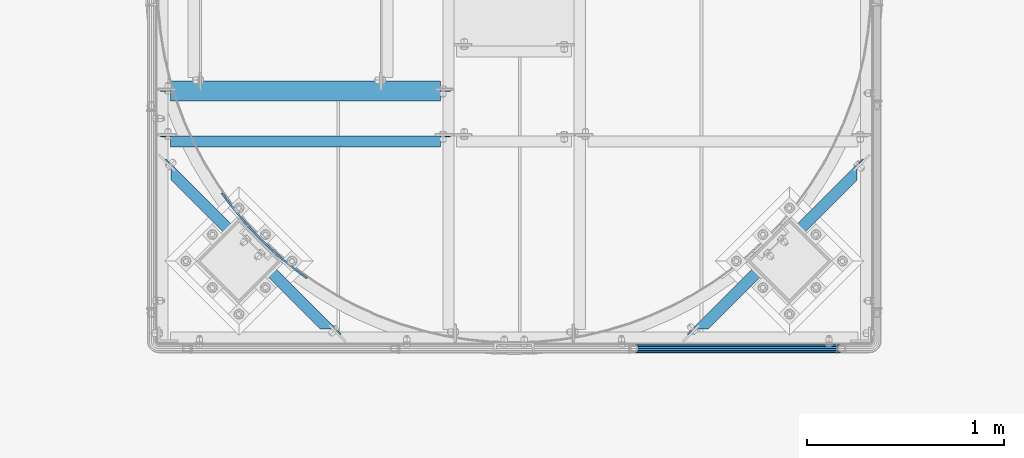
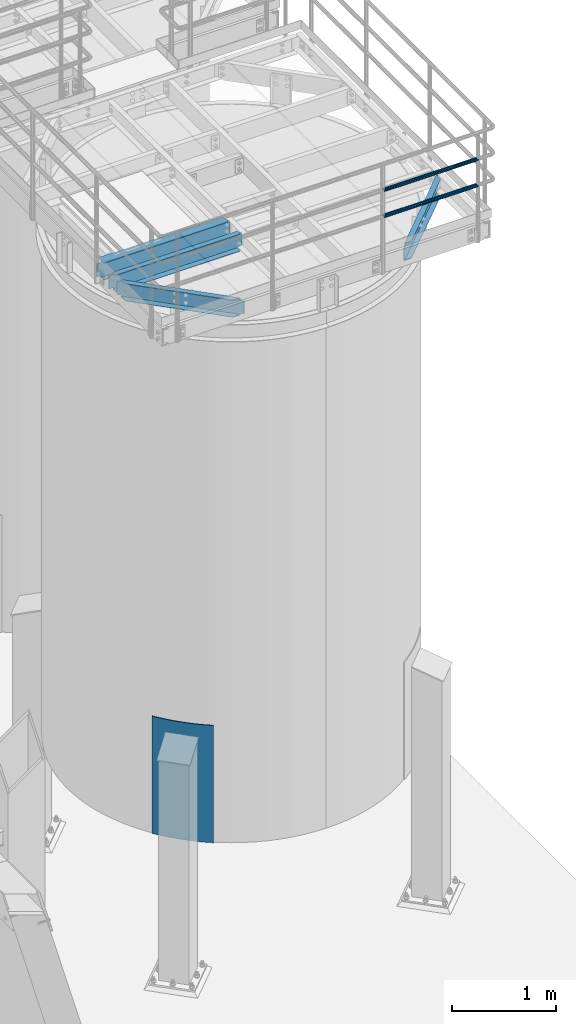
# One storey, part 915 of 1876: 7 beams, 6 elements without a shape of their own.
"""IFC2X3 building model written with IfcOpenShell, lengths in millimetres."""

from ifc_helpers import new_model, si_unit, frame, origin_with_axes, place, context, subcontext, project, spatial, faceted_brep, material, type_object, element, aggregate, save


model = new_model("IFC2X3")

# Units and contexts
model_context = context("Model", 3, precision=1e-05, world=origin_with_axes())
body_context = subcontext(model_context, "Body", "Model", "MODEL_VIEW")
ifc_project = project(units=[si_unit("LENGTHUNIT", "METRE", prefix="MILLI"), si_unit("AREAUNIT", "SQUARE_METRE"), si_unit("VOLUMEUNIT", "CUBIC_METRE"), si_unit("MASSUNIT", "GRAM", prefix="KILO"), si_unit("TIMEUNIT", "SECOND"), si_unit("PLANEANGLEUNIT", "RADIAN"), si_unit("SOLIDANGLEUNIT", "STERADIAN"), si_unit("THERMODYNAMICTEMPERATUREUNIT", "DEGREE_CELSIUS"), si_unit("LUMINOUSINTENSITYUNIT", "LUMEN")], contexts=[model_context])

# Site, building, storey
site_placement = place(None, origin_with_axes())
site = spatial("IfcSite", under=ifc_project, at=site_placement, CompositionType="ELEMENT")
building_placement = place(site_placement, origin_with_axes())
building = spatial("IfcBuilding", under=site, at=building_placement, Name="Undefined", CompositionType="ELEMENT")
storey_placement = place(building_placement, origin_with_axes())
storey = spatial("IfcBuildingStorey", under=building, at=storey_placement, Name="Undefined", CompositionType="ELEMENT", Elevation=0.0)

# Assembly, beams
assembly_1_placement = place(storey_placement, origin_with_axes())
assembly_1 = element("IfcElementAssembly", 1, at=assembly_1_placement, inside=storey, Name="HANDRAIL", AssemblyPlace="NOTDEFINED", PredefinedType="RIGID_FRAME")
ifc_material_1 = material()
beam_type_1 = type_object("IfcBeamType", Name="PIPE1-1/4STD", PredefinedType="NOTDEFINED")
beam_1_placement = place(assembly_1_placement, frame((5791.20143150122, -15432.4964042969, 8480.425), z_axis=(0.0, 0.0, 1.0), x_axis=(1.0, 0.0, 0.0)))
beam_1 = element("IfcBeam", 2, at=beam_1_placement, type_object=beam_type_1, material=ifc_material_1, Name="RAIL", ObjectType="PIPE1-1/4STD", context=body_context, shape_type="Brep", body=[
    faceted_brep([(1035.84245243742, -10.5409999999993, 18.2575475625836), (1035.84245243742, -10.5409999999993, 13.3999612267253), (1035.36603877327, -8.76300000000083, 15.1779612267255), (1033.018, 0.0, 17.5259999999998), (1033.018, 0.0, 21.0820000000003), (1035.36603877327, 8.76300000000083, 15.1779612267255), (1035.84245243742, 10.5409999999993, 13.3999612267253), (1035.84245243742, 10.5409999999993, 18.2575475625836), (1054.1, 21.0820000000003, 0.0), (1043.559, 18.2575475625836, 10.5409999999993), (1043.559, 18.2575475625836, -10.5409999999993), (1040.47941366414, 15.1779612267255, 8.76300000000083), (1042.82745243742, 17.5259999999998, 0.0), (1040.47941366414, 15.1779612267255, -8.76300000000083), (1035.84245243742, 10.5409999999993, -13.3999612267253), (1035.84245243742, 10.5409999999993, -18.2575475625836), (1035.36603877327, 8.76300000000083, -15.1779612267255), (1033.018, 0.0, -17.5259999999998), (1033.018, 0.0, -21.0820000000003), (1035.84245243742, -10.5409999999993, -13.3999612267253), (1035.84245243742, -10.5409999999993, -18.2575475625836), (1035.36603877327, -8.76300000000083, -15.1779612267255), (1054.1, -21.0820000000003, 0.0), (1043.559, -18.2575475625836, -10.5409999999993), (1043.559, -18.2575475625836, 10.5409999999993), (1040.47941366414, -15.1779612267255, -8.76300000000083), (1042.82745243742, -17.5259999999998, 0.0), (1040.47941366414, -15.1779612267255, 8.76300000000083), (10.5409999957128, -18.2575475672238, -10.5409999999993), (18.2575475625817, -10.5410000000011, -18.2575475625836), (9.09494701772928e-13, 21.0820000000003, 0.0), (10.5409999957128, 18.2575475579433, -10.5409999999993), (10.5409999999983, 18.2575475625836, 10.5410000000011), (18.2575475625817, 10.5409999999993, 18.2575475625836), (21.0819999999985, 1.81898940354586e-12, 21.0820000000003), (18.2575475625817, 10.5409999999993, -18.2575475625836), (21.0819999999985, 0.0, -21.0819999999985), (21.0819999999985, 0.0, -17.5259999999998), (18.2575475625817, -10.5409999999974, -13.3999612267271), (18.7339612267233, -8.76300000000083, -15.1779612267255), (18.7339612267251, 8.76299999999901, -15.1779612267255), (18.2575475625817, 10.5410000000011, -13.3999612267235), (13.6205863358573, 15.1779612267255, -8.76299999999901), (11.2725475625839, 17.5259999999998, 0.0), (13.6205863358573, 15.1779612267255, 8.76300000000083), (18.2575475625817, 10.5410000000011, 13.3999612267253), (18.7339612267251, 8.76299999999901, 15.1779612267273), (21.0819999999985, 1.81898940354586e-12, 17.5259999999998), (18.7339612267233, -8.76300000000083, 15.1779612267273), (18.2575475625817, -10.5409999999974, 13.3999612267289), (18.2575475625817, -10.5410000000011, 18.2575475625836), (10.5409999999983, -18.2575475625836, 10.5410000000011), (9.09494701772928e-13, -21.0820000000003, 0.0), (13.6205863358537, -15.1779612267255, 8.76300000000083), (11.2725475625793, -17.5259999999998, 0.0), (13.6205863358537, -15.1779612267255, -8.76299999999901)], [[[0, 1, 2, 3, 4]], [[4, 3, 5, 6, 7]], [[8, 9, 10]], [[7, 6, 11, 12, 13, 14, 15, 10, 9]], [[16, 17, 18, 15, 14]], [[19, 20, 18, 17, 21]], [[22, 23, 24]], [[24, 23, 20, 19, 25, 26, 27, 1, 0]], [[28, 29, 20, 23]], [[30, 31, 32]], [[33, 34, 4, 7]], [[32, 33, 7, 9]], [[30, 32, 9, 8]], [[31, 30, 8, 10]], [[35, 31, 10, 15]], [[36, 35, 15, 18]], [[29, 36, 18, 20]], [[37, 36, 29, 38, 39]], [[40, 41, 35, 36, 37]], [[32, 31, 35, 41, 42, 43, 44, 45, 33]], [[33, 45, 46, 47, 34]], [[34, 47, 48, 49, 50]], [[34, 50, 0, 4]], [[50, 51, 24, 0]], [[51, 52, 22, 24]], [[52, 28, 23, 22]], [[51, 28, 52]], [[50, 49, 53, 54, 55, 38, 29, 28, 51]], [[55, 54, 26, 25]], [[21, 39, 38, 55, 25, 19]], [[37, 39, 21, 17]], [[40, 37, 17, 16]], [[42, 41, 40, 16, 14, 13]], [[43, 42, 13, 12]], [[44, 43, 12, 11]], [[5, 46, 45, 44, 11, 6]], [[47, 46, 5, 3]], [[48, 47, 3, 2]], [[53, 49, 48, 2, 1, 27]], [[54, 53, 27, 26]]]),
])
beam_2_placement = place(assembly_1_placement, frame((6845.30143150122, -15432.4964042969, 8785.225), z_axis=(0.0, 0.0, -1.0), x_axis=(-1.0, 0.0, 0.0)))
beam_2 = element("IfcBeam", 3, at=beam_2_placement, type_object=beam_type_1, material=ifc_material_1, Name="RAIL", ObjectType="PIPE1-1/4STD", context=body_context, shape_type="Brep", body=[
    faceted_brep([(1035.84245243742, -10.5409999999993, 18.2575475625836), (1035.84245243742, -10.5409999999993, 13.3999612267253), (1035.36603877327, -8.76300000000083, 15.1779612267255), (1033.018, 0.0, 17.5259999999998), (1033.018, 0.0, 21.0820000000003), (1035.36603877327, 8.76300000000083, 15.1779612267255), (1035.84245243742, 10.5409999999993, 13.3999612267253), (1035.84245243742, 10.5409999999993, 18.2575475625836), (1054.1, 21.0820000000003, 0.0), (1043.559, 18.2575475625836, 10.5409999999993), (1043.559, 18.2575475625836, -10.5409999999993), (1040.47941366414, 15.1779612267255, 8.76300000000083), (1042.82745243742, 17.5259999999998, 0.0), (1040.47941366414, 15.1779612267255, -8.76300000000083), (1035.84245243742, 10.5409999999993, -13.3999612267253), (1035.84245243742, 10.5409999999993, -18.2575475625836), (1035.36603877327, 8.76300000000083, -15.1779612267255), (1033.018, 0.0, -17.5259999999998), (1033.018, 0.0, -21.0820000000003), (1035.84245243742, -10.5409999999993, -13.3999612267253), (1035.84245243742, -10.5409999999993, -18.2575475625836), (1035.36603877327, -8.76300000000083, -15.1779612267255), (1054.1, -21.0820000000003, 0.0), (1043.559, -18.2575475625836, -10.5409999999993), (1043.559, -18.2575475625836, 10.5409999999993), (1040.47941366414, -15.1779612267255, -8.76300000000083), (1042.82745243742, -17.5259999999998, 0.0), (1040.47941366414, -15.1779612267255, 8.76300000000083), (10.5409999957128, -18.2575475672238, -10.5409999999993), (18.2575475625817, -10.5410000000011, -18.2575475625836), (9.09494701772928e-13, 21.0820000000003, 0.0), (10.5409999957128, 18.2575475579433, -10.5409999999993), (10.5409999999983, 18.2575475625836, 10.5410000000011), (18.2575475625817, 10.5409999999993, 18.2575475625836), (21.0819999999985, 1.81898940354586e-12, 21.0820000000003), (18.2575475625817, 10.5409999999993, -18.2575475625836), (21.0819999999985, 0.0, -21.0819999999985), (21.0819999999985, 0.0, -17.5259999999998), (18.2575475625817, -10.5409999999974, -13.3999612267271), (18.7339612267233, -8.76300000000083, -15.1779612267255), (18.7339612267251, 8.76299999999901, -15.1779612267255), (18.2575475625817, 10.5410000000011, -13.3999612267235), (13.6205863358573, 15.1779612267255, -8.76299999999901), (11.2725475625839, 17.5259999999998, 0.0), (13.6205863358573, 15.1779612267255, 8.76300000000083), (18.2575475625817, 10.5410000000011, 13.3999612267253), (18.7339612267251, 8.76299999999901, 15.1779612267273), (21.0819999999985, 1.81898940354586e-12, 17.5259999999998), (18.7339612267233, -8.76300000000083, 15.1779612267273), (18.2575475625817, -10.5409999999974, 13.3999612267289), (18.2575475625817, -10.5410000000011, 18.2575475625836), (10.5409999999983, -18.2575475625836, 10.5410000000011), (9.09494701772928e-13, -21.0820000000003, 0.0), (13.6205863358537, -15.1779612267255, 8.76300000000083), (11.2725475625793, -17.5259999999998, 0.0), (13.6205863358537, -15.1779612267255, -8.76299999999901)], [[[0, 1, 2, 3, 4]], [[4, 3, 5, 6, 7]], [[8, 9, 10]], [[7, 6, 11, 12, 13, 14, 15, 10, 9]], [[16, 17, 18, 15, 14]], [[19, 20, 18, 17, 21]], [[22, 23, 24]], [[24, 23, 20, 19, 25, 26, 27, 1, 0]], [[28, 29, 20, 23]], [[30, 31, 32]], [[33, 34, 4, 7]], [[32, 33, 7, 9]], [[30, 32, 9, 8]], [[31, 30, 8, 10]], [[35, 31, 10, 15]], [[36, 35, 15, 18]], [[29, 36, 18, 20]], [[37, 36, 29, 38, 39]], [[40, 41, 35, 36, 37]], [[32, 31, 35, 41, 42, 43, 44, 45, 33]], [[33, 45, 46, 47, 34]], [[34, 47, 48, 49, 50]], [[34, 50, 0, 4]], [[50, 51, 24, 0]], [[51, 52, 22, 24]], [[52, 28, 23, 22]], [[51, 28, 52]], [[50, 49, 53, 54, 55, 38, 29, 28, 51]], [[55, 54, 26, 25]], [[21, 39, 38, 55, 25, 19]], [[37, 39, 21, 17]], [[40, 37, 17, 16]], [[42, 41, 40, 16, 14, 13]], [[43, 42, 13, 12]], [[44, 43, 12, 11]], [[5, 46, 45, 44, 11, 6]], [[47, 46, 5, 3]], [[48, 47, 3, 2]], [[53, 49, 48, 2, 1, 27]], [[54, 53, 27, 26]]]),
])
aggregate(assembly_1, [beam_1, beam_2])

# Assembly, beam
assembly_2_placement = place(storey_placement, origin_with_axes())
assembly_2 = element("IfcElementAssembly", 4, at=assembly_2_placement, inside=storey, Name="BEAM", AssemblyPlace="NOTDEFINED", PredefinedType="RIGID_FRAME")
ifc_material_2 = material(Name="STEEL/A36")
beam_type_2 = type_object("IfcBeamType", Name="C8X11.5", PredefinedType="NOTDEFINED")
beam_3_placement = place(assembly_2_placement, frame((6039.01195777118, -15421.1027935693, 7896.225), z_axis=(0.0, 0.0, 1.0), x_axis=(0.707106781186548, 0.707106781186547, 0.0)))
beam_3 = element("IfcBeam", 5, at=beam_3_placement, type_object=beam_type_2, material=ifc_material_2, Name="BEAM", ObjectType="C8X11.5", context=body_context, shape_type="Brep", body=[
    faceted_brep([(154.529650862193, -28.5750000000044, -96.8355949999996), (154.529650862193, -28.5750000000044, -101.6), (1223.93966372655, -28.5750000000035, -101.6), (1223.93966372655, -28.5750000000035, -96.8355949999996), (103.581210715046, 22.225000000004, -88.3723149999996), (106.897026668097, 19.0576241940926, -88.899999809265), (1271.57228792066, 19.0576241941089, -88.8999998092622), (1274.88810387369, 22.225000000004, -88.3723149999996), (85.7691388897797, 22.225000000004, -76.1999999999998), (79.4191388897784, 28.5750000000062, -76.1999999999998), (86.2923292584137, 28.5750000000044, -77.1667299225874), (92.6423292584141, 22.225000000004, -77.1667299225874), (92.1191386990495, 28.5750000000044, -79.9197438230658), (98.4691386990489, 22.2250000000058, -79.9197438230658), (96.0124882945074, 28.5750000000062, -84.0399202912195), (102.362488294509, 22.225000000004, -84.0399202912195), (97.3796508621845, 28.5750000000044, -88.899999809265), (97.3796508621845, 28.5750000000044, -101.6), (1281.08966372656, 28.5750000000062, -101.6), (1281.08966372656, 28.5750000000062, -88.8999998092622), (1282.45682629424, 28.5750000000044, -84.0399202912167), (1276.10682629423, 22.2250000000031, -84.0399202912167), (1286.35017588969, 28.5750000000062, -79.9197438230631), (1280.00017588969, 22.2250000000049, -79.9197438230631), (1292.17698533033, 28.5750000000062, -77.1667299225846), (1285.82698533033, 22.2250000000049, -77.1667299225846), (1299.05017569896, 28.5750000000053, -76.1999999999971), (1292.70017569896, 22.225000000004, -76.1999999999971), (1319.3218385947, 28.5750000000053, -76.1999999999971), (1319.3218385947, 22.225000000004, -76.1999999999971), (1319.3218385947, 28.5750000000053, 76.2000000000016), (1319.3218385947, 22.225000000004, 76.2000000000016), (1299.0501756976, 28.5750000000053, 76.2000000000016), (1292.7001756976, 22.2250000000049, 76.2000000000016), (1292.17698532897, 28.5750000000053, 77.1667299225892), (1285.82698532897, 22.225000000004, 77.1667299225892), (1286.35017588834, 28.5750000000053, 79.9197438230676), (1280.00017588834, 22.225000000004, 79.9197438230676), (1282.45682629288, 28.5750000000044, 84.0399202912213), (1276.10682629288, 22.225000000004, 84.0399202912213), (1281.0896637252, 28.5750000000053, 88.8999998092668), (1271.57228791927, 19.0576241940789, 88.8999998092668), (1274.88810387234, 22.2250000000049, 88.3723149999996), (1281.0896637252, 28.5750000000053, 101.6), (1223.93966372519, -28.5750000000044, 101.6), (1223.93966372519, -28.5750000000044, 96.8355949999996), (97.3796508622331, 28.5750000000062, 101.6), (154.529650862243, -28.5750000000025, 101.6), (154.529650862243, -28.5750000000025, 96.8355949999996), (106.897026668147, 19.0576241940926, 88.899999809265), (103.581210715098, 22.225000000004, 88.3723149999996), (97.3796508622331, 28.5750000000062, 88.899999809265), (96.0124882945579, 28.5750000000062, 84.0399202912195), (102.362488294559, 22.225000000004, 84.0399202912195), (92.119138699099, 28.5750000000062, 79.9197438230658), (98.4691386990994, 22.225000000004, 79.9197438230658), (86.2923292584624, 28.5750000000062, 77.1667299225874), (92.6423292584636, 22.225000000004, 77.1667299225874), (79.4191388898289, 28.5750000000062, 76.1999999999998), (85.7691388898302, 22.225000000004, 76.1999999999998), (59.2796508614138, 22.2250000000058, 76.1999999999953), (59.2796508615056, 22.2250000000058, -76.2000000000044), (59.2796508615047, 28.5750000000044, -76.2000000000044), (59.2796508614128, 28.5750000000044, 76.1999999999953)], [[[0, 1, 2, 3]], [[4, 5, 0, 3, 6, 7]], [[8, 9, 10, 11]], [[11, 10, 12, 13]], [[13, 12, 14, 15]], [[4, 15, 14, 16, 5]], [[0, 5, 16, 17, 1]], [[1, 17, 18, 2]], [[19, 6, 3, 2, 18]], [[20, 21, 7, 6, 19]], [[22, 23, 21, 20]], [[24, 25, 23, 22]], [[26, 27, 25, 24]], [[27, 26, 28, 29]], [[28, 30, 31, 29]], [[32, 33, 31, 30]], [[34, 35, 33, 32]], [[36, 37, 35, 34]], [[38, 39, 37, 36]], [[40, 41, 42, 39, 38]], [[43, 44, 45, 41, 40]], [[46, 47, 44, 43]], [[47, 48, 45, 44]], [[45, 48, 49, 50, 42, 41]], [[47, 46, 51, 49, 48]], [[49, 51, 52, 53, 50]], [[53, 52, 54, 55]], [[55, 54, 56, 57]], [[57, 56, 58, 59]], [[8, 11, 13, 15, 4, 7, 21, 23, 25, 27, 29, 31, 33, 35, 37, 39, 42, 50, 53, 55, 57, 59, 60, 61]], [[9, 8, 61, 62]], [[58, 56, 54, 52, 51, 46, 43, 40, 38, 36, 34, 32, 30, 28, 26, 24, 22, 20, 19, 18, 17, 16, 14, 12, 10, 9, 62, 63]], [[59, 58, 63, 60]], [[62, 61, 60, 63]]]),
])
aggregate(assembly_2, [beam_3])

assembly_3_placement = place(storey_placement, origin_with_axes())
assembly_3 = element("IfcElementAssembly", 6, at=assembly_3_placement, inside=storey, Name="BEAM", AssemblyPlace="NOTDEFINED", PredefinedType="RIGID_FRAME")
beam_4_placement = place(assembly_3_placement, frame((3349.46304222882, -14446.3777935693, 7896.225), z_axis=(0.0, 0.0, 1.0), x_axis=(0.707106781186547, -0.707106781186548, 0.0)))
beam_4 = element("IfcBeam", 7, at=beam_4_placement, type_object=beam_type_2, material=ifc_material_2, Name="BEAM", ObjectType="C8X11.5", context=body_context, shape_type="Brep", body=[
    faceted_brep([(92.6423292584636, 22.225000000004, 77.1667299225874), (86.2923292584624, 28.5750000000062, 77.1667299225874), (79.4191388898289, 28.5750000000062, 76.1999999999998), (85.7691388898302, 22.225000000004, 76.1999999999998), (98.4691386990994, 22.225000000004, 79.9197438230658), (92.119138699099, 28.5750000000062, 79.9197438230658), (102.362488294559, 22.225000000004, 84.0399202912195), (96.0124882945579, 28.5750000000062, 84.0399202912195), (106.897026668147, 19.0576241940926, 88.899999809265), (97.3796508622331, 28.5750000000062, 88.899999809265), (103.581210715098, 22.225000000004, 88.3723149999996), (1223.93966372519, -28.5750000000044, 96.8355949999996), (154.529650862243, -28.5750000000025, 96.8355949999996), (1274.88810387234, 22.2250000000049, 88.3723149999996), (1271.57228791927, 19.0576241940789, 88.8999998092668), (154.529650862243, -28.5750000000025, 101.6), (97.3796508622331, 28.5750000000062, 101.6), (1223.93966372519, -28.5750000000044, 101.6), (1281.0896637252, 28.5750000000053, 101.6), (1292.70017569896, 22.225000000004, -76.1999999999971), (1299.05017569896, 28.5750000000053, -76.1999999999971), (1319.3218385947, 28.5750000000053, -76.1999999999971), (1319.3218385947, 22.225000000004, -76.1999999999971), (1285.82698533033, 22.2250000000049, -77.1667299225846), (1292.17698533033, 28.5750000000062, -77.1667299225846), (1280.00017588969, 22.2250000000049, -79.9197438230631), (1286.35017588969, 28.5750000000062, -79.9197438230631), (1276.10682629423, 22.2250000000031, -84.0399202912167), (1282.45682629424, 28.5750000000044, -84.0399202912167), (1274.88810387369, 22.225000000004, -88.3723149999996), (1271.57228792066, 19.0576241941089, -88.8999998092622), (1281.08966372656, 28.5750000000062, -88.8999998092622), (103.581210715046, 22.225000000004, -88.3723149999996), (106.897026668097, 19.0576241940926, -88.899999809265), (154.529650862193, -28.5750000000044, -96.8355949999996), (1223.93966372655, -28.5750000000035, -96.8355949999996), (154.529650862193, -28.5750000000044, -101.6), (1223.93966372655, -28.5750000000035, -101.6), (1281.08966372656, 28.5750000000062, -101.6), (97.3796508621845, 28.5750000000044, -101.6), (97.3796508621845, 28.5750000000044, -88.899999809265), (102.362488294509, 22.225000000004, -84.0399202912195), (96.0124882945074, 28.5750000000062, -84.0399202912195), (98.4691386990489, 22.2250000000058, -79.9197438230658), (92.1191386990495, 28.5750000000044, -79.9197438230658), (92.6423292584141, 22.225000000004, -77.1667299225874), (86.2923292584137, 28.5750000000044, -77.1667299225874), (85.7691388897797, 22.225000000004, -76.1999999999998), (79.4191388897784, 28.5750000000062, -76.1999999999998), (59.1474759898592, 22.225000000004, -76.1999999999998), (59.1474759898588, 28.5750000000062, -76.1999999999998), (1281.0896637252, 28.5750000000053, 88.8999998092668), (1282.45682629288, 28.5750000000044, 84.0399202912213), (1286.35017588834, 28.5750000000053, 79.9197438230676), (1292.17698532897, 28.5750000000053, 77.1667299225892), (1299.0501756976, 28.5750000000053, 76.2000000000016), (1319.3218385947, 28.5750000000053, 76.2000000000016), (59.1474759898588, 28.5750000000062, 76.1999999999998), (59.1474759898592, 22.225000000004, 76.1999999999998), (1319.3218385947, 22.225000000004, 76.2000000000016), (1292.7001756976, 22.2250000000049, 76.2000000000016), (1285.82698532897, 22.225000000004, 77.1667299225892), (1280.00017588834, 22.225000000004, 79.9197438230676), (1276.10682629288, 22.225000000004, 84.0399202912213)], [[[0, 1, 2, 3]], [[4, 5, 1, 0]], [[6, 7, 5, 4]], [[8, 9, 7, 6, 10]], [[11, 12, 8, 10, 13, 14]], [[15, 16, 9, 8, 12]], [[16, 15, 17, 18]], [[19, 20, 21, 22]], [[20, 19, 23, 24]], [[24, 23, 25, 26]], [[26, 25, 27, 28]], [[28, 27, 29, 30, 31]], [[32, 33, 34, 35, 30, 29]], [[34, 36, 37, 35]], [[31, 30, 35, 37, 38]], [[36, 39, 38, 37]], [[34, 33, 40, 39, 36]], [[32, 41, 42, 40, 33]], [[43, 44, 42, 41]], [[45, 46, 44, 43]], [[47, 48, 46, 45]], [[48, 47, 49, 50]], [[2, 1, 5, 7, 9, 16, 18, 51, 52, 53, 54, 55, 56, 21, 20, 24, 26, 28, 31, 38, 39, 40, 42, 44, 46, 48, 50, 57]], [[3, 2, 57, 58]], [[50, 49, 58, 57]], [[47, 45, 43, 41, 32, 29, 27, 25, 23, 19, 22, 59, 60, 61, 62, 63, 13, 10, 6, 4, 0, 3, 58, 49]], [[21, 56, 59, 22]], [[55, 60, 59, 56]], [[54, 61, 60, 55]], [[53, 62, 61, 54]], [[52, 63, 62, 53]], [[51, 14, 13, 63, 52]], [[18, 17, 11, 14, 51]], [[15, 12, 11, 17]]]),
])
aggregate(assembly_3, [beam_4])

assembly_4_placement = place(storey_placement, origin_with_axes())
assembly_4 = element("IfcElementAssembly", 8, at=assembly_4_placement, inside=storey, Name="BEAM", AssemblyPlace="NOTDEFINED", PredefinedType="RIGID_FRAME")
beam_5_placement = place(assembly_4_placement, frame((3365.50143150122, -14379.5394042969, 7896.225), z_axis=(0.0, 0.0, 1.0), x_axis=(1.0, 0.0, 0.0)))
beam_5 = element("IfcBeam", 9, at=beam_5_placement, type_object=beam_type_2, material=ifc_material_2, Name="BEAM", ObjectType="C8X11.5", context=body_context, shape_type="Brep", body=[
    faceted_brep([(1441.45, -28.5750000000007, -96.8355949999996), (1441.45, -28.5750000000007, -101.6), (1441.45, 28.5750000000007, -101.6), (1441.45, 28.5750000000007, -88.899999809264), (1441.45, 19.0576241940926, -88.899999809264), (1441.55496303464, 22.2250000000004, -88.3723149999996), (1442.41672992259, 28.5750000000007, -84.0399202912186), (1442.41672992259, 22.2250000000004, -84.0399202912186), (1445.16974382306, 28.5750000000007, -79.9197438230649), (1445.16974382306, 22.2250000000004, -79.9197438230649), (1449.28992029122, 28.5750000000007, -77.1667299225865), (1449.28992029122, 22.2250000000004, -77.1667299225865), (1454.14999980926, 28.5750000000007, -76.1999999999989), (1454.14999980926, 22.2250000000004, -76.1999999999989), (1492.25, 22.2250000000004, -76.1999999999989), (1492.25, 28.5750000000007, -76.1999999999989), (69.8500000000013, 28.5750000000007, 101.6), (69.8500000000013, -28.5750000000007, 101.6), (1441.45, -28.5750000000007, 101.6), (1441.45, 28.5750000000007, 101.6), (69.8500000000013, 19.0576241940817, -88.8999998092659), (69.8500000000013, 28.5750000000007, -88.8999998092659), (69.8500000000013, 28.5750000000007, -101.6), (69.8500000000013, -28.5750000000007, -101.6), (69.8500000000013, -28.5750000000007, -96.8355949999996), (69.7450369653598, 22.2250000000004, -88.3723149999996), (68.8832700774137, 22.2250000000004, -84.0399202912204), (68.8832700774137, 28.5750000000007, -84.0399202912204), (66.1302561769353, 22.2250000000004, -79.9197438230667), (66.1302561769353, 28.5750000000007, -79.9197438230667), (62.0100797087816, 22.2250000000004, -77.1667299225883), (62.0100797087816, 28.5750000000007, -77.1667299225883), (57.1500001907361, 22.2250000000004, -76.2000000000007), (57.1500001907361, 28.5750000000007, -76.2000000000007), (19.0499999999993, 22.2250000000004, -76.2000000000007), (19.0499999999993, 28.5750000000007, -76.2000000000007), (19.0499999999993, 22.2250000000004, 76.1999999999989), (19.0499999999993, 28.5750000000007, 76.1999999999989), (57.1500001907361, 22.2250000000004, 76.1999999999989), (57.1500001907361, 28.5750000000007, 76.1999999999989), (62.0100797087816, 22.2250000000004, 77.1667299225865), (62.0100797087816, 28.5750000000007, 77.1667299225865), (66.1302561769353, 22.2250000000004, 79.9197438230649), (66.1302561769353, 28.5750000000007, 79.9197438230649), (68.8832700774137, 22.2250000000004, 84.0399202912186), (68.8832700774137, 28.5750000000007, 84.0399202912186), (69.8500000000013, 19.0576241940926, 88.899999809264), (69.8500000000013, 28.5750000000007, 88.899999809264), (69.7450369653607, 22.2250000000004, 88.3723149999996), (69.8500000000013, -28.5750000000007, 96.8355949999996), (1441.45, -28.5750000000007, 96.8355949999996), (1441.45, 19.0576241940817, 88.8999998092659), (1441.45, 28.5750000000007, 88.8999998092659), (1441.55496303464, 22.2250000000004, 88.3723149999996), (1442.41672992259, 22.2250000000004, 84.0399202912204), (1442.41672992259, 28.5750000000007, 84.0399202912204), (1445.16974382306, 22.2250000000004, 79.9197438230667), (1445.16974382306, 28.5750000000007, 79.9197438230667), (1449.28992029122, 22.2250000000004, 77.1667299225883), (1449.28992029122, 28.5750000000007, 77.1667299225883), (1454.14999980926, 22.2250000000004, 76.2000000000007), (1454.14999980926, 28.5750000000007, 76.2000000000007), (1492.25, 22.2250000000004, 76.2000000000007), (1492.25, 28.5750000000007, 76.2000000000007)], [[[0, 1, 2, 3, 4]], [[5, 4, 3, 6, 7]], [[7, 6, 8, 9]], [[9, 8, 10, 11]], [[11, 10, 12, 13]], [[14, 13, 12, 15]], [[16, 17, 18, 19]], [[20, 21, 22, 23, 24]], [[25, 26, 27, 21, 20]], [[28, 29, 27, 26]], [[30, 31, 29, 28]], [[32, 33, 31, 30]], [[34, 35, 33, 32]], [[36, 37, 35, 34]], [[38, 39, 37, 36]], [[40, 41, 39, 38]], [[42, 43, 41, 40]], [[44, 45, 43, 42]], [[46, 47, 45, 44, 48]], [[17, 16, 47, 46, 49]], [[17, 49, 50, 18]], [[18, 50, 51, 52, 19]], [[49, 46, 48, 53, 51, 50]], [[54, 55, 52, 51, 53]], [[56, 57, 55, 54]], [[58, 59, 57, 56]], [[60, 61, 59, 58]], [[62, 63, 61, 60]], [[63, 62, 14, 15]], [[10, 8, 6, 3, 2, 22, 21, 27, 29, 31, 33, 35, 37, 39, 41, 43, 45, 47, 16, 19, 52, 55, 57, 59, 61, 63, 15, 12]], [[23, 22, 2, 1]], [[24, 23, 1, 0]], [[25, 20, 24, 0, 4, 5]], [[62, 60, 58, 56, 54, 53, 48, 44, 42, 40, 38, 36, 34, 32, 30, 28, 26, 25, 5, 7, 9, 11, 13, 14]]]),
])
aggregate(assembly_4, [beam_5])

assembly_5_placement = place(storey_placement, origin_with_axes())
assembly_5 = element("IfcElementAssembly", 10, at=assembly_5_placement, inside=storey, Name="BEAM", AssemblyPlace="NOTDEFINED", PredefinedType="RIGID_FRAME")
ifc_material_3 = material(Name="STEEL/A992")
beam_type_3 = type_object("IfcBeamType", Name="W8X13", PredefinedType="NOTDEFINED")
beam_6_placement = place(assembly_5_placement, frame((3365.50143150122, -14122.3644042969, 7896.225), z_axis=(0.0, 0.0, 1.0), x_axis=(1.0, 0.0, 0.0)))
beam_6 = element("IfcBeam", 11, at=beam_6_placement, type_object=beam_type_3, material=ifc_material_3, Name="BEAM", ObjectType="W8X13", context=body_context, shape_type="Brep", body=[
    faceted_brep([(19.0499999999997, -3.17499999999927, -76.4599999999991), (19.0499999999997, 3.17499999999927, -76.4599999999991), (57.1499996230009, 3.17499999999927, -76.4599999999991), (57.1499996230009, -3.17499999999927, -76.4599999999991), (62.0100791410464, 3.17499999999927, -77.4267299225867), (62.0100791410464, -3.17499999999927, -77.4267299225867), (66.1302556092, 3.17499999999927, -80.1797438230651), (66.1302556092, -3.17499999999927, -80.1797438230651), (68.883269509678, 3.17499999999927, -84.2999202912188), (68.883269509678, -3.17499999999927, -84.2999202912188), (69.849999432266, -3.17499999999927, -89.1599998092643), (69.849999432266, 3.17499999999927, -89.1599998092643), (69.849999432266, 3.17499999999927, -95.25), (69.849999432266, 50.7999999999993, -95.25), (69.849999432266, 50.7999999999993, -101.6), (69.849999432266, -50.7999999999993, -101.6), (69.849999432266, -50.7999999999993, -95.25), (69.849999432266, -3.17499999999927, -95.25), (69.8500006943577, 3.17500000000018, 95.25), (69.8500006943577, 50.8000000000002, 95.25), (1441.45000056773, 50.7999999999993, 95.25), (1441.45000056773, 3.17499999999927, 95.25), (57.1499996230009, -3.17499999999927, 75.9400016784675), (57.1499996230009, 3.17499999999927, 75.9400016784675), (19.0499999999997, 3.17499999999927, 75.9400016784675), (19.0499999999997, -3.17499999999927, 75.9400016784675), (62.0100791410464, -3.17499999999927, 76.9067316010551), (62.0100791410464, 3.17499999999927, 76.9067316010551), (66.1302556092, -3.17499999999927, 79.6597455015335), (66.1302556092, 3.17499999999927, 79.6597455015335), (68.883269509678, -3.17499999999927, 83.7799219696872), (68.883269509678, 3.17499999999927, 83.7799219696872), (69.849999432266, -3.17499999999927, 88.6400014877327), (69.849999432266, 3.17499999999927, 88.6400014877327), (69.849999432266, 50.7999999999993, 101.6), (69.849999432266, -50.7999999999993, 101.6), (1441.45000056773, -50.7999999999993, 101.6), (1441.45000056773, 50.7999999999993, 101.6), (69.8500006943577, -50.8000000000002, 95.25), (1441.45000056773, -50.7999999999993, 95.25), (69.8500006943577, -3.17500000000018, 95.25), (1441.45000056773, -3.17499999999927, 95.25), (1441.45000056773, -3.17499999999927, 88.6400014877308), (1441.45000056773, 3.17499999999927, 88.6400014877308), (1442.41673049032, -3.17499999999927, 83.7799219696853), (1442.41673049032, 3.17499999999927, 83.7799219696853), (1445.1697443908, -3.17499999999927, 79.6597455015317), (1445.1697443908, 3.17499999999927, 79.6597455015317), (1449.28992085895, -3.17499999999927, 76.9067316010533), (1449.28992085895, 3.17499999999927, 76.9067316010533), (1454.150000377, -3.17499999999927, 75.9400016784657), (1454.150000377, 3.17499999999927, 75.9400016784657), (1492.25, -3.17499999999927, 75.9400016784657), (1492.25, 3.17499999999927, 75.9400016784657), (1492.25, -3.17499999999927, -76.4600000000009), (1492.25, 3.17499999999927, -76.4600000000009), (1454.150000377, -3.17499999999927, -76.4600000000009), (1454.150000377, 3.17499999999927, -76.4600000000009), (1449.28992085895, -3.17499999999927, -77.4267299225885), (1449.28992085895, 3.17499999999927, -77.4267299225885), (1445.1697443908, -3.17499999999927, -80.1797438230669), (1445.1697443908, 3.17499999999927, -80.1797438230669), (1442.41673049032, -3.17499999999927, -84.2999202912206), (1442.41673049032, 3.17499999999927, -84.2999202912206), (1441.45000056773, -3.17499999999927, -89.1599998092661), (1441.45000056773, 3.17499999999927, -89.1599998092661), (1441.45000056773, -3.17499999999927, -95.25), (1441.45000056773, -50.7999999999993, -95.25), (1441.45000056773, -50.7999999999993, -101.6), (1441.45000056773, 50.7999999999993, -101.6), (1441.45000056773, 50.7999999999993, -95.25), (1441.45000056773, 3.17499999999927, -95.25)], [[[0, 1, 2, 3]], [[3, 2, 4, 5]], [[5, 4, 6, 7]], [[7, 6, 8, 9]], [[10, 11, 12, 13, 14, 15, 16, 17]], [[9, 8, 11, 10]], [[18, 19, 20, 21]], [[22, 23, 24, 25]], [[26, 27, 23, 22]], [[28, 29, 27, 26]], [[30, 31, 29, 28]], [[32, 33, 31, 30]], [[34, 35, 36, 37]], [[35, 38, 39, 36]], [[38, 40, 41, 39]], [[35, 34, 19, 18, 33, 32, 40, 38]], [[19, 34, 37, 20]], [[36, 39, 41, 42, 43, 21, 20, 37]], [[44, 45, 43, 42]], [[46, 47, 45, 44]], [[48, 49, 47, 46]], [[50, 51, 49, 48]], [[52, 53, 51, 50]], [[53, 52, 54, 55]], [[54, 56, 57, 55]], [[58, 59, 57, 56]], [[60, 61, 59, 58]], [[62, 63, 61, 60]], [[64, 65, 63, 62]], [[66, 67, 68, 69, 70, 71, 65, 64]], [[17, 16, 67, 66]], [[16, 15, 68, 67]], [[15, 14, 69, 68]], [[14, 13, 70, 69]], [[13, 12, 71, 70]], [[59, 61, 63, 65, 71, 12, 11, 8, 6, 4, 2, 1, 24, 23, 27, 29, 31, 33, 18, 21, 43, 45, 47, 49, 51, 53, 55, 57]], [[25, 24, 1, 0]], [[52, 50, 48, 46, 44, 42, 41, 40, 32, 30, 28, 26, 22, 25, 0, 3, 5, 7, 9, 10, 17, 66, 64, 62, 60, 58, 56, 54]]]),
])
aggregate(assembly_5, [beam_6])

assembly_6_placement = place(storey_placement, origin_with_axes())
assembly_6 = element("IfcElementAssembly", 12, at=assembly_6_placement, inside=storey, Name="COLUMN", AssemblyPlace="NOTDEFINED", PredefinedType="RIGID_FRAME")
beam_type_4 = type_object("IfcBeamType", PredefinedType="NOTDEFINED")
beam_7_placement = place(assembly_6_placement, frame((4128.4104793459, -15074.3721979111, 2209.8), z_axis=(0.0, 0.0, 1.0), x_axis=(-0.707106781186548, 0.707106781186547, 0.0)))
beam_7 = element("IfcBeam", 13, at=beam_7_placement, type_object=beam_type_4, material=ifc_material_2, Name="PLATE", context=body_context, shape_type="Brep", body=[
    faceted_brep([(-0.79930179960138, 4.6949465261232, -685.8), (-0.79930179960138, 4.6949465261232, 685.8), (60.0611937621743, 14.0031633272019, 685.8), (60.0611937621743, 14.0031633272019, -685.8), (0.79930179960138, -4.6949465261232, 685.8), (0.79930179960138, -4.6949465261232, -685.8), (61.3422639062264, 4.56470559905301, -685.8), (61.3422639062264, 4.56470559905301, 685.8), (121.200950016122, 21.2538891700888, 685.8), (121.200950016122, 21.2538891700888, -685.8), (122.163029690721, 11.7776015161735, -685.8), (122.163029690721, 11.7776015161735, 685.8), (182.550430177147, 26.4388775030229, 685.8), (182.550430177147, 26.4388775030229, -685.8), (183.192425169107, 16.9355376990206, -685.8), (183.192425169107, 16.9355376990206, 685.8), (244.039858932445, 29.5522312233416, 685.8), (244.039858932445, 29.5522312233416, -685.8), (244.361039074185, 20.0326478124689, -685.8), (244.361039074185, 20.0326478124689, 685.8), (305.599301799859, 30.5904093845011, 685.8), (305.599301799859, 30.5904093845011, -685.8), (305.599301799861, 21.0654093844987, -685.8), (305.599301799861, 21.0654093844987, 685.8), (367.158744667275, 29.5522312233416, 685.8), (367.158744667275, 29.5522312233416, -685.8), (366.837564525536, 20.0326478124671, -685.8), (366.837564525536, 20.0326478124671, 685.8), (428.648173422573, 26.4388775030238, 685.8), (428.648173422573, 26.4388775030238, -685.8), (428.006178430616, 16.9355376990216, -685.8), (428.006178430616, 16.9355376990216, 685.8), (489.997653583598, 21.2538891700897, 685.8), (489.997653583598, 21.2538891700897, -685.8), (489.035573908999, 11.7776015161735, -685.8), (489.035573908999, 11.7776015161735, 685.8), (551.137409837545, 14.0031633272019, 685.8), (551.137409837545, 14.0031633272019, -685.8), (549.856339693495, 4.56470559905301, -685.8), (549.856339693495, 4.56470559905301, 685.8), (611.997905399321, 4.6949465261232, 685.8), (611.997905399321, 4.6949465261232, -685.8), (610.399301800118, -4.69494652612411, 685.8), (610.399301800118, -4.69494652612411, -685.8)], [[[0, 1, 2, 3]], [[4, 5, 6, 7]], [[5, 4, 1, 0]], [[3, 2, 8, 9]], [[7, 6, 10, 11]], [[9, 8, 12, 13]], [[11, 10, 14, 15]], [[13, 12, 16, 17]], [[15, 14, 18, 19]], [[17, 16, 20, 21]], [[19, 18, 22, 23]], [[21, 20, 24, 25]], [[23, 22, 26, 27]], [[25, 24, 28, 29]], [[27, 26, 30, 31]], [[29, 28, 32, 33]], [[31, 30, 34, 35]], [[33, 32, 36, 37]], [[35, 34, 38, 39]], [[37, 36, 40, 41]], [[36, 32, 28, 24, 20, 16, 12, 8, 2, 1, 4, 7, 11, 15, 19, 23, 27, 31, 35, 39, 42, 40]], [[39, 38, 43, 42]], [[38, 34, 30, 26, 22, 18, 14, 10, 6, 5, 0, 3, 9, 13, 17, 21, 25, 29, 33, 37, 41, 43]], [[42, 43, 41, 40]]]),
])
aggregate(assembly_6, [beam_7])

save(model, "model.ifc")
